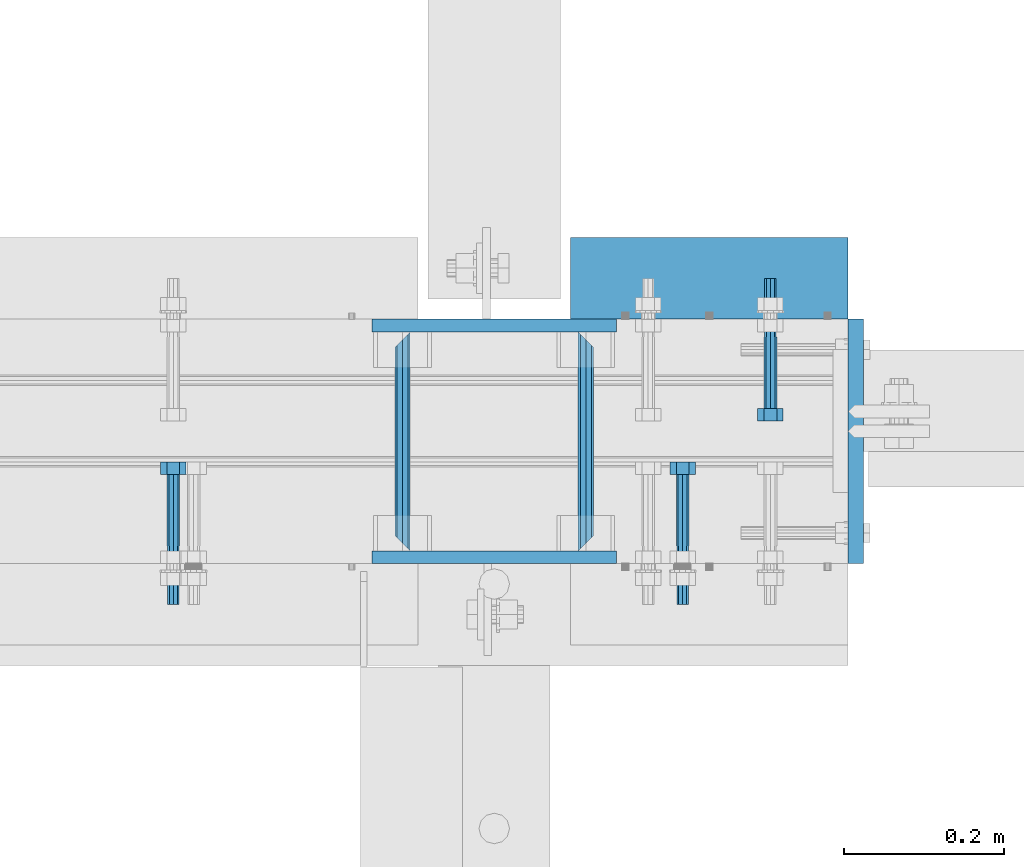
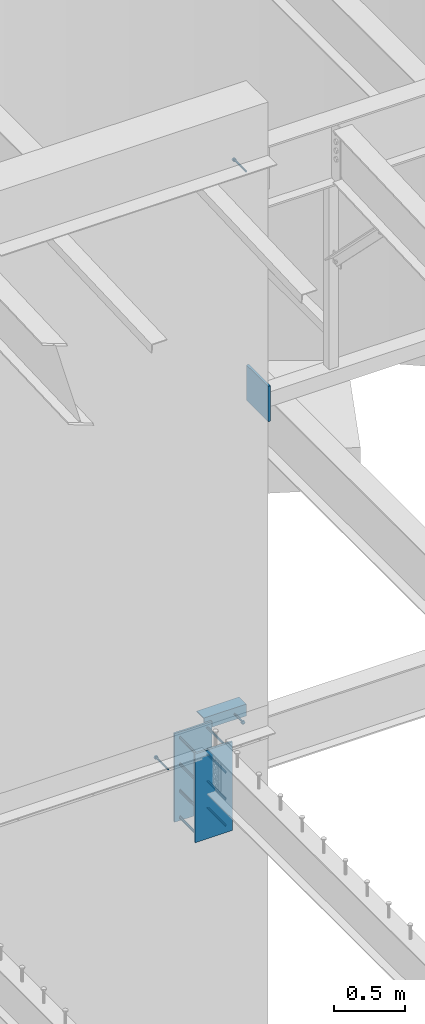
# One storey, part 443 of 975: 15 beams.
"""IFC2X3 building model written with IfcOpenShell, lengths in millimetres."""

from ifc_helpers import new_model, si_unit, frame, origin_with_axes, place, context, subcontext, project, spatial, faceted_brep, material, type_object, element, save


model = new_model("IFC2X3")

# Units and contexts
model_context = context("Model", 3, precision=1e-05, world=origin_with_axes())
body_context = subcontext(model_context, "Body", "Model", "MODEL_VIEW")
ifc_project = project(units=[si_unit("LENGTHUNIT", "METRE", prefix="MILLI"), si_unit("AREAUNIT", "SQUARE_METRE"), si_unit("VOLUMEUNIT", "CUBIC_METRE"), si_unit("MASSUNIT", "GRAM", prefix="KILO"), si_unit("TIMEUNIT", "SECOND"), si_unit("PLANEANGLEUNIT", "RADIAN"), si_unit("SOLIDANGLEUNIT", "STERADIAN"), si_unit("THERMODYNAMICTEMPERATUREUNIT", "DEGREE_CELSIUS"), si_unit("LUMINOUSINTENSITYUNIT", "LUMEN")], contexts=[model_context])

# Site, building, storey
site_placement = place(None, origin_with_axes())
site = spatial("IfcSite", under=ifc_project, at=site_placement, CompositionType="ELEMENT")
building_placement = place(site_placement, origin_with_axes())
building = spatial("IfcBuilding", under=site, at=building_placement, Name="Undefined", CompositionType="ELEMENT")
storey_placement = place(building_placement, origin_with_axes())
storey = spatial("IfcBuildingStorey", under=building, at=storey_placement, Name="Undefined", CompositionType="ELEMENT", Elevation=0.0)

# Beams
ifc_material_1 = material(Name="STEEL/F1554-36")
beam_type_1 = type_object("IfcBeamType", PredefinedType="NOTDEFINED")
beam_1_placement = place(storey_placement, frame((13722.3499919693, 20466.0499990482, 8801.10000031656), z_axis=(0.0, 0.0, -1.0), x_axis=(0.0, 1.0, 0.0)))
element("IfcBeam", 1, at=beam_1_placement, inside=storey, type_object=beam_type_1, material=ifc_material_1, Name="HEADED_ANCHOR_BOLT", context=body_context, shape_type="Brep", body=[
    faceted_brep([(88.9000000184824, 7.94000001861696, -13.7499999799138), (88.8999999527368, 15.8800000758411, 2.00943759409711e-08), (104.774999952569, 15.8800001213949, 6.97191353538074e-08), (104.775000018315, 7.94000006417082, -13.7499999302891), (88.900000064019, -7.94000009583215, -13.7499999799147), (104.775000063852, -7.9400000502792, -13.74999993029), (88.9000000438027, -15.880000153059, 2.00925569515675e-08), (104.775000043643, -15.8800001075042, 6.9716406869702e-08), (88.8999999780608, -7.94000009583488, 13.7500000200998), (104.774999977893, -7.94000005028101, 13.7500000697237), (88.8999999325279, 7.94000001861514, 13.7500000201007), (104.774999932361, 7.940000064169, 13.7500000697246), (88.9000000119959, 3.78780480527439, -7.86545778426807), (88.8999999957159, 6.82538844544797, -5.4430656647246), (88.8999999799416, 8.51112018845743, -1.94260763148395), (88.8999999677944, 8.51112018845652, 1.94260767167179), (88.8999999616899, 6.82538844544615, 5.44306570491244), (88.8999999628249, 3.78780480527257, 7.86545782445592), (88.8999999709849, -3.86089595849626e-08, 8.72999956233434), (88.8999999845473, -3.7878048824914, 7.8654578244541), (88.9000000008309, -6.82538852266407, 5.44306570491153), (88.9000000166052, -8.51112026567444, 1.94260767166998), (88.9000000287488, -8.51112026567353, -1.94260763148577), (88.9000000348606, -6.82538852266407, -5.44306566472642), (88.9000000337182, -3.78780488248958, -7.86545778426898), (88.9000000255583, -3.86080500902608e-08, -8.72999952214832), (104.775000025395, 6.94581103743985e-09, -8.72999947252447), (104.775000011829, 3.78780485082825, -7.86545773464422), (104.774999995549, 6.82538849100092, -5.44306561510075), (104.774999979774, 8.51112023401038, -1.9426075818601), (104.774999967627, 8.51112023401038, 1.94260772129564), (104.774999961523, 6.82538849100092, 5.44306575453629), (104.774999962658, 3.78780485082643, 7.86545787407977), (104.774999970818, 6.94399204803631e-09, 8.7299996119591), (104.77499998438, -3.78780483693754, 7.86545787407886), (104.775000000664, -6.82538847711112, 5.44306575453538), (104.775000016438, -8.51112022012057, 1.94260772129473), (104.775000028581, -8.51112022012057, -1.94260758186101), (104.775000034693, -6.82538847711021, -5.44306561510166), (104.775000033551, -3.78780483693663, -7.86545773464422), (-2.99107341561466e-07, -5.61266007567065, 5.61266007566792), (-4.22995071858168e-07, -7.93750000000728, 0.0), (104.774999998088, -7.93749999999, -4.45652403868735e-11), (104.774999998088, -5.61266007565791, 5.61266007562426), (-1.09139364212751e-11, 1.81898940354586e-12, 7.9375), (104.774999998095, 1.18234311230481e-11, 7.93749999995816), (2.99089151667431e-07, 5.61266007567428, 5.61266007566792), (104.774999998102, 5.61266007568065, 5.61266007562517), (4.22980519942939e-07, 7.93750000001091, 0.0), (104.77499999811, 7.93750000001364, -4.36557456851006e-11), (2.99089151667431e-07, 5.61266007567428, -5.61266007566792), (104.774999998102, 5.61266007568156, -5.61266007571339), (-1.09139364212751e-11, 1.81898940354586e-12, -7.9375), (104.774999998099, 1.2732925824821e-11, -7.93750000004547), (-73.0249999592124, 5.05157065939329, -5.0515715445581), (-73.0249999269472, -1.85405951924622e-07, -7.14400069976364), (-73.0249999328516, -5.0515710302052, -5.05157154455992), (-73.0249999734697, -7.14400018541073, -6.9975976657588e-07), (-73.0250000250016, -5.05157103020611, 5.05157014504039), (-73.0250000572705, -1.85406861419324e-07, 7.1439993002441), (-73.0250000513661, 5.05157065939238, 5.05157014503948), (-73.025000010748, 7.14399981459792, -6.99758857081179e-07), (0.00625003290042514, 5.05157085007795, -5.05157087849238), (0.00625006516929716, 5.27870724909008e-09, -7.1440000336961), (0.00625005926485755, -5.05157083952145, -5.05157087849329), (0.00625001864682417, -7.14399999472516, -3.36940502165817e-08), (0.00624996711121639, -5.05157083952145, 5.05157081110519), (0.00624993484598235, 5.2777977543883e-09, 7.14399996631164), (0.00624994074678398, 5.05157085007704, 5.05157081110701), (0.00624998136845534, 7.14400000528167, -3.36922312271781e-08), (-2.99107341561466e-07, -5.61266007567065, -5.61266007566792), (104.774999998092, -5.612660075657, -5.6126600757143)], [[[0, 1, 2, 3]], [[4, 0, 3, 5]], [[6, 4, 5, 7]], [[8, 6, 7, 9]], [[10, 8, 9, 11]], [[0, 4, 6, 8, 10, 1], [12, 13, 14, 15, 16, 17, 18, 19, 20, 21, 22, 23, 24, 25]], [[12, 25, 26, 27]], [[13, 12, 27, 28]], [[14, 13, 28, 29]], [[15, 14, 29, 30]], [[16, 15, 30, 31]], [[17, 16, 31, 32]], [[18, 17, 32, 33]], [[19, 18, 33, 34]], [[20, 19, 34, 35]], [[21, 20, 35, 36]], [[22, 21, 36, 37]], [[23, 22, 37, 38]], [[24, 23, 38, 39]], [[25, 24, 39, 26]], [[9, 7, 5, 3, 2, 11], [38, 37, 36, 35, 34, 33, 32, 31, 30, 29, 28, 27, 26, 39]], [[1, 10, 11, 2]], [[40, 41, 42, 43]], [[44, 40, 43, 45]], [[46, 44, 45, 47]], [[48, 46, 47, 49]], [[50, 48, 49, 51]], [[52, 50, 51, 53]], [[54, 55, 56, 57, 58, 59, 60, 61]], [[55, 54, 62, 63]], [[56, 55, 63, 64]], [[57, 56, 64, 65]], [[58, 57, 65, 66]], [[59, 58, 66, 67]], [[60, 59, 67, 68]], [[61, 60, 68, 69]], [[54, 61, 69, 62]], [[40, 44, 46, 48, 50, 52, 70, 41], [68, 67, 66, 65, 64, 63, 62, 69]], [[41, 70, 71, 42]], [[53, 51, 49, 47, 45, 43, 42, 71]], [[70, 52, 53, 71]]]),
])
beam_2_placement = place(storey_placement, frame((13831.8874969214, 20726.3999997605, 3886.2), z_axis=(0.0, 0.0, 1.0), x_axis=(0.0, -1.0, 0.0)))
element("IfcBeam", 2, at=beam_2_placement, inside=storey, type_object=beam_type_1, material=ifc_material_1, Name="HEADED_ANCHOR_BOLT", context=body_context, shape_type="Brep", body=[
    faceted_brep([(88.9000000184824, 7.94000001861696, -13.7499999799138), (88.8999999527368, 15.8800000758411, 2.00943759409711e-08), (104.774999952569, 15.8800001213949, 6.97191353538074e-08), (104.775000018315, 7.94000006417082, -13.7499999302891), (88.900000064019, -7.94000009583215, -13.7499999799147), (104.775000063852, -7.9400000502792, -13.74999993029), (88.9000000438027, -15.880000153059, 2.00925569515675e-08), (104.775000043643, -15.8800001075042, 6.9716406869702e-08), (88.8999999780608, -7.94000009583488, 13.7500000200998), (104.774999977893, -7.94000005028101, 13.7500000697237), (88.8999999325279, 7.94000001861514, 13.7500000201007), (104.774999932361, 7.940000064169, 13.7500000697246), (88.9000000119959, 3.78780480527439, -7.86545778426807), (88.8999999957159, 6.82538844544797, -5.4430656647246), (88.8999999799416, 8.51112018845743, -1.94260763148395), (88.8999999677944, 8.51112018845652, 1.94260767167179), (88.8999999616899, 6.82538844544615, 5.44306570491244), (88.8999999628249, 3.78780480527257, 7.86545782445592), (88.8999999709849, -3.86089595849626e-08, 8.72999956233434), (88.8999999845473, -3.7878048824914, 7.8654578244541), (88.9000000008309, -6.82538852266407, 5.44306570491153), (88.9000000166052, -8.51112026567444, 1.94260767166998), (88.9000000287488, -8.51112026567353, -1.94260763148577), (88.9000000348606, -6.82538852266407, -5.44306566472642), (88.9000000337182, -3.78780488248958, -7.86545778426898), (88.9000000255583, -3.86080500902608e-08, -8.72999952214832), (104.775000025395, 6.94581103743985e-09, -8.72999947252447), (104.775000011829, 3.78780485082825, -7.86545773464422), (104.774999995549, 6.82538849100092, -5.44306561510075), (104.774999979774, 8.51112023401038, -1.9426075818601), (104.774999967627, 8.51112023401038, 1.94260772129564), (104.774999961523, 6.82538849100092, 5.44306575453629), (104.774999962658, 3.78780485082643, 7.86545787407977), (104.774999970818, 6.94399204803631e-09, 8.7299996119591), (104.77499998438, -3.78780483693754, 7.86545787407886), (104.775000000664, -6.82538847711112, 5.44306575453538), (104.775000016438, -8.51112022012057, 1.94260772129473), (104.775000028581, -8.51112022012057, -1.94260758186101), (104.775000034693, -6.82538847711021, -5.44306561510166), (104.775000033551, -3.78780483693663, -7.86545773464422), (-2.99107341561466e-07, -5.61266007567065, 5.61266007566792), (-4.22995071858168e-07, -7.93750000000728, 0.0), (104.774999998088, -7.93749999999, -4.45652403868735e-11), (104.774999998088, -5.61266007565791, 5.61266007562426), (-1.09139364212751e-11, 1.81898940354586e-12, 7.9375), (104.774999998095, 1.18234311230481e-11, 7.93749999995816), (2.99089151667431e-07, 5.61266007567428, 5.61266007566792), (104.774999998102, 5.61266007568065, 5.61266007562517), (4.22980519942939e-07, 7.93750000001091, 0.0), (104.77499999811, 7.93750000001364, -4.36557456851006e-11), (2.99089151667431e-07, 5.61266007567428, -5.61266007566792), (104.774999998102, 5.61266007568156, -5.61266007571339), (-1.09139364212751e-11, 1.81898940354586e-12, -7.9375), (104.774999998099, 1.2732925824821e-11, -7.93750000004547), (-73.0249999592124, 5.05157065939329, -5.0515715445581), (-73.0249999269472, -1.85405951924622e-07, -7.14400069976364), (-73.0249999328516, -5.0515710302052, -5.05157154455992), (-73.0249999734697, -7.14400018541073, -6.9975976657588e-07), (-73.0250000250016, -5.05157103020611, 5.05157014504039), (-73.0250000572705, -1.85406861419324e-07, 7.1439993002441), (-73.0250000513661, 5.05157065939238, 5.05157014503948), (-73.025000010748, 7.14399981459792, -6.99758857081179e-07), (0.00625003290042514, 5.05157085007795, -5.05157087849238), (0.00625006516929716, 5.27870724909008e-09, -7.1440000336961), (0.00625005926485755, -5.05157083952145, -5.05157087849329), (0.00625001864682417, -7.14399999472516, -3.36940502165817e-08), (0.00624996711121639, -5.05157083952145, 5.05157081110519), (0.00624993484598235, 5.2777977543883e-09, 7.14399996631164), (0.00624994074678398, 5.05157085007704, 5.05157081110701), (0.00624998136845534, 7.14400000528167, -3.36922312271781e-08), (-2.99107341561466e-07, -5.61266007567065, -5.61266007566792), (104.774999998092, -5.612660075657, -5.6126600757143)], [[[0, 1, 2, 3]], [[4, 0, 3, 5]], [[6, 4, 5, 7]], [[8, 6, 7, 9]], [[10, 8, 9, 11]], [[0, 4, 6, 8, 10, 1], [12, 13, 14, 15, 16, 17, 18, 19, 20, 21, 22, 23, 24, 25]], [[12, 25, 26, 27]], [[13, 12, 27, 28]], [[14, 13, 28, 29]], [[15, 14, 29, 30]], [[16, 15, 30, 31]], [[17, 16, 31, 32]], [[18, 17, 32, 33]], [[19, 18, 33, 34]], [[20, 19, 34, 35]], [[21, 20, 35, 36]], [[22, 21, 36, 37]], [[23, 22, 37, 38]], [[24, 23, 38, 39]], [[25, 24, 39, 26]], [[9, 7, 5, 3, 2, 11], [38, 37, 36, 35, 34, 33, 32, 31, 30, 29, 28, 27, 26, 39]], [[1, 10, 11, 2]], [[40, 41, 42, 43]], [[44, 40, 43, 45]], [[46, 44, 45, 47]], [[48, 46, 47, 49]], [[50, 48, 49, 51]], [[52, 50, 51, 53]], [[54, 55, 56, 57, 58, 59, 60, 61]], [[55, 54, 62, 63]], [[56, 55, 63, 64]], [[57, 56, 64, 65]], [[58, 57, 65, 66]], [[59, 58, 66, 67]], [[60, 59, 67, 68]], [[61, 60, 68, 69]], [[54, 61, 69, 62]], [[40, 44, 46, 48, 50, 52, 70, 41], [68, 67, 66, 65, 64, 63, 62, 69]], [[41, 70, 71, 42]], [[53, 51, 49, 47, 45, 43, 42, 71]], [[70, 52, 53, 71]]]),
])
beam_3_placement = place(storey_placement, frame((13087.3500244105, 20466.05, 3886.2), z_axis=(0.0, 0.0, -1.0), x_axis=(0.0, 1.0, 0.0)))
element("IfcBeam", 3, at=beam_3_placement, inside=storey, type_object=beam_type_1, material=ifc_material_1, Name="HEADED_ANCHOR_BOLT", context=body_context, shape_type="Brep", body=[
    faceted_brep([(88.9000000184824, 7.94000001861696, -13.7499999799138), (88.8999999527368, 15.8800000758411, 2.00943759409711e-08), (104.774999952569, 15.8800001213949, 6.97191353538074e-08), (104.775000018315, 7.94000006417082, -13.7499999302891), (88.900000064019, -7.94000009583215, -13.7499999799147), (104.775000063852, -7.9400000502792, -13.74999993029), (88.9000000438027, -15.880000153059, 2.00925569515675e-08), (104.775000043643, -15.8800001075042, 6.9716406869702e-08), (88.8999999780608, -7.94000009583488, 13.7500000200998), (104.774999977893, -7.94000005028101, 13.7500000697237), (88.8999999325279, 7.94000001861514, 13.7500000201007), (104.774999932361, 7.940000064169, 13.7500000697246), (88.9000000119959, 3.78780480527439, -7.86545778426807), (88.8999999957159, 6.82538844544797, -5.4430656647246), (88.8999999799416, 8.51112018845743, -1.94260763148395), (88.8999999677944, 8.51112018845652, 1.94260767167179), (88.8999999616899, 6.82538844544615, 5.44306570491244), (88.8999999628249, 3.78780480527257, 7.86545782445592), (88.8999999709849, -3.86089595849626e-08, 8.72999956233434), (88.8999999845473, -3.7878048824914, 7.8654578244541), (88.9000000008309, -6.82538852266407, 5.44306570491153), (88.9000000166052, -8.51112026567444, 1.94260767166998), (88.9000000287488, -8.51112026567353, -1.94260763148577), (88.9000000348606, -6.82538852266407, -5.44306566472642), (88.9000000337182, -3.78780488248958, -7.86545778426898), (88.9000000255583, -3.86080500902608e-08, -8.72999952214832), (104.775000025395, 6.94581103743985e-09, -8.72999947252447), (104.775000011829, 3.78780485082825, -7.86545773464422), (104.774999995549, 6.82538849100092, -5.44306561510075), (104.774999979774, 8.51112023401038, -1.9426075818601), (104.774999967627, 8.51112023401038, 1.94260772129564), (104.774999961523, 6.82538849100092, 5.44306575453629), (104.774999962658, 3.78780485082643, 7.86545787407977), (104.774999970818, 6.94399204803631e-09, 8.7299996119591), (104.77499998438, -3.78780483693754, 7.86545787407886), (104.775000000664, -6.82538847711112, 5.44306575453538), (104.775000016438, -8.51112022012057, 1.94260772129473), (104.775000028581, -8.51112022012057, -1.94260758186101), (104.775000034693, -6.82538847711021, -5.44306561510166), (104.775000033551, -3.78780483693663, -7.86545773464422), (-2.99107341561466e-07, -5.61266007567065, 5.61266007566792), (-4.22995071858168e-07, -7.93750000000728, 0.0), (104.774999998088, -7.93749999999, -4.45652403868735e-11), (104.774999998088, -5.61266007565791, 5.61266007562426), (-1.09139364212751e-11, 1.81898940354586e-12, 7.9375), (104.774999998095, 1.18234311230481e-11, 7.93749999995816), (2.99089151667431e-07, 5.61266007567428, 5.61266007566792), (104.774999998102, 5.61266007568065, 5.61266007562517), (4.22980519942939e-07, 7.93750000001091, 0.0), (104.77499999811, 7.93750000001364, -4.36557456851006e-11), (2.99089151667431e-07, 5.61266007567428, -5.61266007566792), (104.774999998102, 5.61266007568156, -5.61266007571339), (-1.09139364212751e-11, 1.81898940354586e-12, -7.9375), (104.774999998099, 1.2732925824821e-11, -7.93750000004547), (-73.0249999592124, 5.05157065939329, -5.0515715445581), (-73.0249999269472, -1.85405951924622e-07, -7.14400069976364), (-73.0249999328516, -5.0515710302052, -5.05157154455992), (-73.0249999734697, -7.14400018541073, -6.9975976657588e-07), (-73.0250000250016, -5.05157103020611, 5.05157014504039), (-73.0250000572705, -1.85406861419324e-07, 7.1439993002441), (-73.0250000513661, 5.05157065939238, 5.05157014503948), (-73.025000010748, 7.14399981459792, -6.99758857081179e-07), (0.00625003290042514, 5.05157085007795, -5.05157087849238), (0.00625006516929716, 5.27870724909008e-09, -7.1440000336961), (0.00625005926485755, -5.05157083952145, -5.05157087849329), (0.00625001864682417, -7.14399999472516, -3.36940502165817e-08), (0.00624996711121639, -5.05157083952145, 5.05157081110519), (0.00624993484598235, 5.2777977543883e-09, 7.14399996631164), (0.00624994074678398, 5.05157085007704, 5.05157081110701), (0.00624998136845534, 7.14400000528167, -3.36922312271781e-08), (-2.99107341561466e-07, -5.61266007567065, -5.61266007566792), (104.774999998092, -5.612660075657, -5.6126600757143)], [[[0, 1, 2, 3]], [[4, 0, 3, 5]], [[6, 4, 5, 7]], [[8, 6, 7, 9]], [[10, 8, 9, 11]], [[0, 4, 6, 8, 10, 1], [12, 13, 14, 15, 16, 17, 18, 19, 20, 21, 22, 23, 24, 25]], [[12, 25, 26, 27]], [[13, 12, 27, 28]], [[14, 13, 28, 29]], [[15, 14, 29, 30]], [[16, 15, 30, 31]], [[17, 16, 31, 32]], [[18, 17, 32, 33]], [[19, 18, 33, 34]], [[20, 19, 34, 35]], [[21, 20, 35, 36]], [[22, 21, 36, 37]], [[23, 22, 37, 38]], [[24, 23, 38, 39]], [[25, 24, 39, 26]], [[9, 7, 5, 3, 2, 11], [38, 37, 36, 35, 34, 33, 32, 31, 30, 29, 28, 27, 26, 39]], [[1, 10, 11, 2]], [[40, 41, 42, 43]], [[44, 40, 43, 45]], [[46, 44, 45, 47]], [[48, 46, 47, 49]], [[50, 48, 49, 51]], [[52, 50, 51, 53]], [[54, 55, 56, 57, 58, 59, 60, 61]], [[55, 54, 62, 63]], [[56, 55, 63, 64]], [[57, 56, 64, 65]], [[58, 57, 65, 66]], [[59, 58, 66, 67]], [[60, 59, 67, 68]], [[61, 60, 68, 69]], [[54, 61, 69, 62]], [[40, 44, 46, 48, 50, 52, 70, 41], [68, 67, 66, 65, 64, 63, 62, 69]], [[41, 70, 71, 42]], [[53, 51, 49, 47, 45, 43, 42, 71]], [[70, 52, 53, 71]]]),
])
ifc_material_2 = material(Name="STEEL/A36")
beam_type_2 = type_object("IfcBeamType", Name="L4X4X5/16", PredefinedType="NOTDEFINED")
beam_4_placement = place(storey_placement, frame((13928.7250000424, 20799.4249996637, 3886.2), z_axis=(0.0, 1.0, 0.0), x_axis=(-0.999999999999998, 6.90000001668524e-08, 0.0)))
element("IfcBeam", 4, at=beam_4_placement, inside=storey, type_object=beam_type_2, material=ifc_material_2, Name="LEDGER_ANGLE", ObjectType="L4X4X5/16", context=body_context, shape_type="Brep", body=[
    faceted_brep([(-1.90993887372315e-11, 50.8000000000002, -50.8), (2.00088834390044e-11, 50.8000000000002, 50.8), (346.075000009081, 50.8000000000002, 50.8000000001557), (346.075000009127, 50.8000000000002, -50.7999999998465), (2.00088834390044e-11, 42.8625000000002, 50.8), (346.075000009081, 42.8625000000002, 50.8000000001557), (-1.63709046319127e-11, 42.8625000000002, -42.8625), (346.075000009121, 42.8625000000002, -42.8624999998465), (-1.63709046319127e-11, -50.8000000000002, -42.8625), (346.075000009121, -50.8000000000002, -42.8624999998465), (-1.90993887372315e-11, -50.8000000000002, -50.8), (346.075000009127, -50.8000000000002, -50.7999999998465)], [[[0, 1, 2, 3]], [[1, 4, 5, 2]], [[4, 6, 7, 5]], [[6, 8, 9, 7]], [[8, 10, 11, 9]], [[10, 0, 3, 11]], [[5, 7, 9, 11, 3, 2]], [[10, 8, 6, 4, 1, 0]]]),
])
beam_type_3 = type_object("IfcBeamType", PredefinedType="NOTDEFINED")
beam_5_placement = place(storey_placement, frame((13938.25, 20748.625, 6699.25), z_axis=(0.0, 0.0, 1.0), x_axis=(0.0, -1.0, 0.0)))
element("IfcBeam", 5, at=beam_5_placement, inside=storey, type_object=beam_type_3, material=ifc_material_2, Name="PLATE", context=body_context, shape_type="Brep", body=[
    faceted_brep([(0.0, 9.52499999999964, -152.4), (0.0, 9.52499999999964, 152.4), (304.799999999152, 9.52499999999964, 152.4), (304.799999999152, 9.52499999999964, -152.4), (0.0, -9.52499999999964, 152.4), (304.799999999152, -9.52499999999964, 152.4), (0.0, -9.52499999999964, -152.4), (304.799999999152, -9.52499999999964, -152.4)], [[[0, 1, 2, 3]], [[1, 4, 5, 2]], [[4, 6, 7, 5]], [[6, 0, 3, 7]], [[5, 7, 3, 2]], [[6, 4, 1, 0]]]),
])
beam_type_4 = type_object("IfcBeamType", PredefinedType="NOTDEFINED")
beam_6_placement = place(storey_placement, frame((13601.7, 20459.7, 3403.6), z_axis=(0.0, 0.0, 1.0), x_axis=(0.0, 1.0, 0.0)))
element("IfcBeam", 6, at=beam_6_placement, inside=storey, type_object=beam_type_4, material=ifc_material_2, Name="ROD", context=body_context, shape_type="Brep", body=[
    faceted_brep([(19.0499992370605, -9.52499923706273, 0.0), (16.2601920907982, -6.73519209080223, 6.73519209080177), (9.52499999999782, 0.0, 9.52500000000009), (2.78980790919741, 6.73519209080223, 6.73519209080177), (0.0, 9.52499999999964, 0.0), (2.78980790919741, 6.73519209080223, -6.73519209080177), (9.52499999999782, 0.0, -9.52500000000009), (16.2601920907982, -6.73519209080223, -6.73519209080177), (273.050000000003, 9.52499999999782, 0.0), (270.260192090806, 6.73519209080223, 6.73519209080177), (263.525000000005, 0.0, 9.52500000000009), (256.789807909205, -6.73519209080223, 6.73519209080177), (254.000000762942, -9.52499999999964, 0.0), (256.789807909205, -6.73519209080223, -6.73519209080177), (263.525000000005, 0.0, -9.52500000000009), (270.260192090806, 6.73519209080223, -6.73519209080177)], [[[0, 1, 2, 3, 4, 5, 6, 7]], [[8, 9, 10, 11, 12, 13, 14, 15]], [[13, 12, 0, 7]], [[14, 13, 7, 6]], [[15, 14, 6, 5]], [[8, 15, 5, 4]], [[9, 8, 4, 3]], [[10, 9, 3, 2]], [[11, 10, 2, 1]], [[12, 11, 1, 0]]]),
])
beam_7_placement = place(storey_placement, frame((13373.1, 20459.7, 3403.6), z_axis=(0.0, 0.0, 1.0), x_axis=(0.0, 1.0, 0.0)))
element("IfcBeam", 7, at=beam_7_placement, inside=storey, type_object=beam_type_4, material=ifc_material_2, Name="ROD", context=body_context, shape_type="Brep", body=[
    faceted_brep([(19.0499992370605, 9.52499923706091, 0.0), (16.2601920908019, 6.73519209080223, -6.73519209080177), (9.52499999999782, 0.0, -9.52500000000009), (2.78980790919741, -6.73519209080223, -6.73519209080177), (0.0, -9.52499999999964, 0.0), (2.78980790919741, -6.73519209080223, 6.73519209080177), (9.52499999999782, 0.0, 9.52500000000009), (16.2601920908019, 6.73519209080223, 6.73519209080177), (273.050000000003, -9.52499999999964, 0.0), (270.260192090806, -6.73519209080223, -6.73519209080177), (263.525000000005, 0.0, -9.52500000000009), (256.789807909201, 6.73519209080223, -6.73519209080177), (254.000000762942, 9.52499999999964, 0.0), (256.789807909201, 6.73519209080223, 6.73519209080177), (263.525000000005, 0.0, 9.52500000000009), (270.260192090806, -6.73519209080223, 6.73519209080177)], [[[0, 1, 2, 3, 4, 5, 6, 7]], [[8, 9, 10, 11, 12, 13, 14, 15]], [[13, 12, 0, 7]], [[14, 13, 7, 6]], [[15, 14, 6, 5]], [[8, 15, 5, 4]], [[9, 8, 4, 3]], [[10, 9, 3, 2]], [[11, 10, 2, 1]], [[12, 11, 1, 0]]]),
])
beam_8_placement = place(storey_placement, frame((13601.7, 20459.7, 3632.2), z_axis=(0.0, 0.0, 1.0), x_axis=(0.0, 1.0, 0.0)))
element("IfcBeam", 8, at=beam_8_placement, inside=storey, type_object=beam_type_4, material=ifc_material_2, Name="ROD", context=body_context, shape_type="Brep", body=[
    faceted_brep([(19.0499992370605, -9.52499923706273, 0.0), (16.2601920907982, -6.73519209080223, 6.73519209080177), (9.52499999999782, 0.0, 9.52500000000009), (2.78980790919741, 6.73519209080223, 6.73519209080177), (0.0, 9.52499999999964, 0.0), (2.78980790919741, 6.73519209080223, -6.73519209080177), (9.52499999999782, 0.0, -9.52500000000009), (16.2601920907982, -6.73519209080223, -6.73519209080177), (273.050000000003, 9.52499999999782, 0.0), (270.260192090806, 6.73519209080223, 6.73519209080177), (263.525000000005, 0.0, 9.52500000000009), (256.789807909205, -6.73519209080223, 6.73519209080177), (254.000000762942, -9.52499999999964, 0.0), (256.789807909205, -6.73519209080223, -6.73519209080177), (263.525000000005, 0.0, -9.52500000000009), (270.260192090806, 6.73519209080223, -6.73519209080177)], [[[0, 1, 2, 3, 4, 5, 6, 7]], [[8, 9, 10, 11, 12, 13, 14, 15]], [[13, 12, 0, 7]], [[14, 13, 7, 6]], [[15, 14, 6, 5]], [[8, 15, 5, 4]], [[9, 8, 4, 3]], [[10, 9, 3, 2]], [[11, 10, 2, 1]], [[12, 11, 1, 0]]]),
])
beam_9_placement = place(storey_placement, frame((13373.1, 20459.7, 3632.2), z_axis=(0.0, 0.0, 1.0), x_axis=(0.0, 1.0, 0.0)))
element("IfcBeam", 9, at=beam_9_placement, inside=storey, type_object=beam_type_4, material=ifc_material_2, Name="ROD", context=body_context, shape_type="Brep", body=[
    faceted_brep([(19.0499992370605, 9.52499923706091, 0.0), (16.2601920908019, 6.73519209080223, -6.73519209080177), (9.52499999999782, 0.0, -9.52500000000009), (2.78980790919741, -6.73519209080223, -6.73519209080177), (0.0, -9.52499999999964, 0.0), (2.78980790919741, -6.73519209080223, 6.73519209080177), (9.52499999999782, 0.0, 9.52500000000009), (16.2601920908019, 6.73519209080223, 6.73519209080177), (273.050000000003, -9.52499999999964, 0.0), (270.260192090806, -6.73519209080223, -6.73519209080177), (263.525000000005, 0.0, -9.52500000000009), (256.789807909201, 6.73519209080223, -6.73519209080177), (254.000000762942, 9.52499999999964, 0.0), (256.789807909201, 6.73519209080223, 6.73519209080177), (263.525000000005, 0.0, 9.52500000000009), (270.260192090806, -6.73519209080223, 6.73519209080177)], [[[0, 1, 2, 3, 4, 5, 6, 7]], [[8, 9, 10, 11, 12, 13, 14, 15]], [[13, 12, 0, 7]], [[14, 13, 7, 6]], [[15, 14, 6, 5]], [[8, 15, 5, 4]], [[9, 8, 4, 3]], [[10, 9, 3, 2]], [[11, 10, 2, 1]], [[12, 11, 1, 0]]]),
])
beam_10_placement = place(storey_placement, frame((13601.7, 20459.7, 3175.0), z_axis=(0.0, 0.0, 1.0), x_axis=(0.0, 1.0, 0.0)))
element("IfcBeam", 10, at=beam_10_placement, inside=storey, type_object=beam_type_4, material=ifc_material_2, Name="ROD", context=body_context, shape_type="Brep", body=[
    faceted_brep([(19.0499992370605, -9.52499923706273, 0.0), (16.2601920907982, -6.73519209080223, 6.73519209080177), (9.52499999999782, 0.0, 9.52500000000009), (2.78980790919741, 6.73519209080223, 6.73519209080177), (0.0, 9.52499999999964, 0.0), (2.78980790919741, 6.73519209080223, -6.73519209080177), (9.52499999999782, 0.0, -9.52500000000009), (16.2601920907982, -6.73519209080223, -6.73519209080177), (273.050000000003, 9.52499999999782, 0.0), (270.260192090806, 6.73519209080223, 6.73519209080177), (263.525000000005, 0.0, 9.52500000000009), (256.789807909205, -6.73519209080223, 6.73519209080177), (254.000000762942, -9.52499999999964, 0.0), (256.789807909205, -6.73519209080223, -6.73519209080177), (263.525000000005, 0.0, -9.52500000000009), (270.260192090806, 6.73519209080223, -6.73519209080177)], [[[0, 1, 2, 3, 4, 5, 6, 7]], [[8, 9, 10, 11, 12, 13, 14, 15]], [[13, 12, 0, 7]], [[14, 13, 7, 6]], [[15, 14, 6, 5]], [[8, 15, 5, 4]], [[9, 8, 4, 3]], [[10, 9, 3, 2]], [[11, 10, 2, 1]], [[12, 11, 1, 0]]]),
])
beam_11_placement = place(storey_placement, frame((13373.1, 20459.7, 3175.0), z_axis=(0.0, 0.0, 1.0), x_axis=(0.0, 1.0, 0.0)))
element("IfcBeam", 11, at=beam_11_placement, inside=storey, type_object=beam_type_4, material=ifc_material_2, Name="ROD", context=body_context, shape_type="Brep", body=[
    faceted_brep([(19.0499992370605, 9.52499923706091, 0.0), (16.2601920908019, 6.73519209080223, -6.73519209080177), (9.52499999999782, 0.0, -9.52500000000009), (2.78980790919741, -6.73519209080223, -6.73519209080177), (0.0, -9.52499999999964, 0.0), (2.78980790919741, -6.73519209080223, 6.73519209080177), (9.52499999999782, 0.0, 9.52500000000009), (16.2601920908019, 6.73519209080223, 6.73519209080177), (273.050000000003, -9.52499999999964, 0.0), (270.260192090806, -6.73519209080223, -6.73519209080177), (263.525000000005, 0.0, -9.52500000000009), (256.789807909201, 6.73519209080223, -6.73519209080177), (254.000000762942, 9.52499999999964, 0.0), (256.789807909201, 6.73519209080223, 6.73519209080177), (263.525000000005, 0.0, 9.52500000000009), (270.260192090806, -6.73519209080223, 6.73519209080177)], [[[0, 1, 2, 3, 4, 5, 6, 7]], [[8, 9, 10, 11, 12, 13, 14, 15]], [[13, 12, 0, 7]], [[14, 13, 7, 6]], [[15, 14, 6, 5]], [[8, 15, 5, 4]], [[9, 8, 4, 3]], [[10, 9, 3, 2]], [[11, 10, 2, 1]], [[12, 11, 1, 0]]]),
])
beam_12_placement = place(storey_placement, frame((13601.7, 20459.7, 3860.8), z_axis=(0.0, 0.0, 1.0), x_axis=(0.0, 1.0, 0.0)))
element("IfcBeam", 12, at=beam_12_placement, inside=storey, type_object=beam_type_4, material=ifc_material_2, Name="ROD", context=body_context, shape_type="Brep", body=[
    faceted_brep([(19.0499992370605, -9.52499923706273, 0.0), (16.2601920907982, -6.73519209080223, 6.73519209080177), (9.52499999999782, 0.0, 9.52500000000009), (2.78980790919741, 6.73519209080223, 6.73519209080177), (0.0, 9.52499999999964, 0.0), (2.78980790919741, 6.73519209080223, -6.73519209080177), (9.52499999999782, 0.0, -9.52500000000009), (16.2601920907982, -6.73519209080223, -6.73519209080177), (273.050000000003, 9.52499999999782, 0.0), (270.260192090806, 6.73519209080223, 6.73519209080177), (263.525000000005, 0.0, 9.52500000000009), (256.789807909205, -6.73519209080223, 6.73519209080177), (254.000000762942, -9.52499999999964, 0.0), (256.789807909205, -6.73519209080223, -6.73519209080177), (263.525000000005, 0.0, -9.52500000000009), (270.260192090806, 6.73519209080223, -6.73519209080177)], [[[0, 1, 2, 3, 4, 5, 6, 7]], [[8, 9, 10, 11, 12, 13, 14, 15]], [[13, 12, 0, 7]], [[14, 13, 7, 6]], [[15, 14, 6, 5]], [[8, 15, 5, 4]], [[9, 8, 4, 3]], [[10, 9, 3, 2]], [[11, 10, 2, 1]], [[12, 11, 1, 0]]]),
])
beam_13_placement = place(storey_placement, frame((13373.1, 20459.7, 3860.8), z_axis=(0.0, 0.0, 1.0), x_axis=(0.0, 1.0, 0.0)))
element("IfcBeam", 13, at=beam_13_placement, inside=storey, type_object=beam_type_4, material=ifc_material_2, Name="ROD", context=body_context, shape_type="Brep", body=[
    faceted_brep([(19.0499992370605, 9.52499923706091, 0.0), (16.2601920908019, 6.73519209080223, -6.73519209080177), (9.52499999999782, 0.0, -9.52500000000009), (2.78980790919741, -6.73519209080223, -6.73519209080177), (0.0, -9.52499999999964, 0.0), (2.78980790919741, -6.73519209080223, 6.73519209080177), (9.52499999999782, 0.0, 9.52500000000009), (16.2601920908019, 6.73519209080223, 6.73519209080177), (273.050000000003, -9.52499999999964, 0.0), (270.260192090806, -6.73519209080223, -6.73519209080177), (263.525000000005, 0.0, -9.52500000000009), (256.789807909201, 6.73519209080223, -6.73519209080177), (254.000000762942, 9.52499999999964, 0.0), (256.789807909201, 6.73519209080223, 6.73519209080177), (263.525000000005, 0.0, 9.52500000000009), (270.260192090806, -6.73519209080223, 6.73519209080177)], [[[0, 1, 2, 3, 4, 5, 6, 7]], [[8, 9, 10, 11, 12, 13, 14, 15]], [[13, 12, 0, 7]], [[14, 13, 7, 6]], [[15, 14, 6, 5]], [[8, 15, 5, 4]], [[9, 8, 4, 3]], [[10, 9, 3, 2]], [[11, 10, 2, 1]], [[12, 11, 1, 0]]]),
])
beam_type_5 = type_object("IfcBeamType", PredefinedType="NOTDEFINED")
for number, where, z_axis, x_axis, name in (
    (14, (13335.0, 20451.7625, 3517.9), (0.0, 0.0, 1.0), (1.0, 0.0, 0.0), "EMBED_PLATE"),
    (15, (13335.0, 20740.6875, 3517.9), (0.0, 0.0, 1.0), (1.0, 0.0, 0.0), "EMBED_PLATE"),
):
    element("IfcBeam", number, at=place(storey_placement, frame(where, z_axis=z_axis, x_axis=x_axis)), inside=storey, type_object=beam_type_5, material=ifc_material_2, Name=name, context=body_context, shape_type="Brep", body=[
        faceted_brep([(0.0, 7.9375, -381.0), (0.0, 7.9375, 381.0), (304.800000000001, 7.9375, 381.0), (304.800000000001, 7.9375, -381.0), (0.0, -7.9375, 381.0), (304.800000000001, -7.9375, 381.0), (0.0, -7.9375, -381.0), (304.800000000001, -7.9375, -381.0)], [[[0, 1, 2, 3]], [[1, 4, 5, 2]], [[4, 6, 7, 5]], [[6, 0, 3, 7]], [[5, 7, 3, 2]], [[6, 4, 1, 0]]]),
    ])

save(model, "model.ifc")
